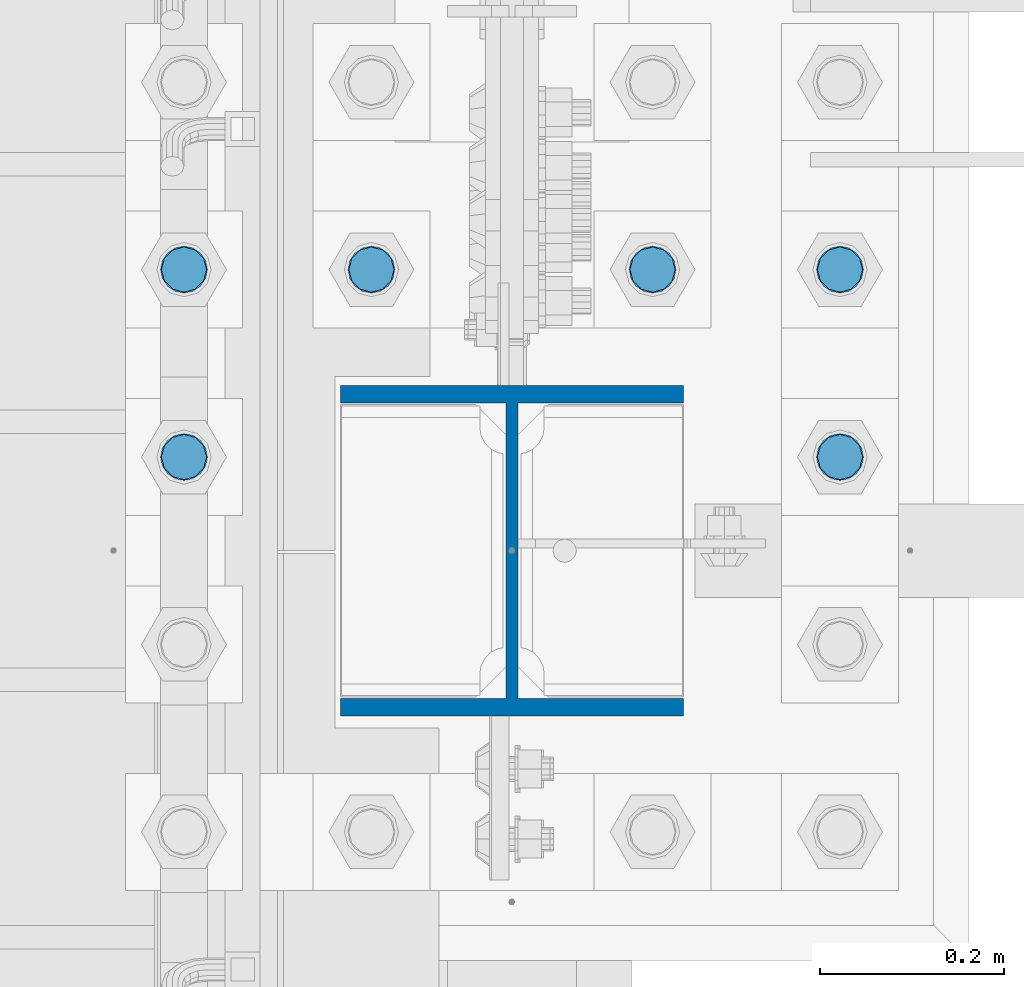
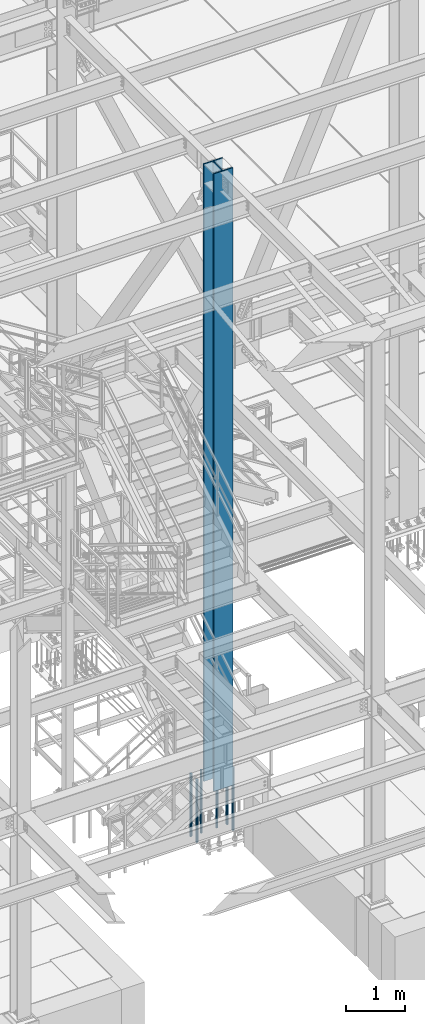
# One storey, part 1296 of 3843: 7 columns, 2 elements without a shape of their own.
"""IFC2X3 building model written with IfcOpenShell, lengths in millimetres."""

import ifcopenshell
import ifcopenshell.guid

model = None  # the IFC model being written
_history = None  # IfcOwnerHistory: only IFC2X3 demands one
_inside = {}  # id of a spatial element -> (the spatial element, [elements in it])
_under = {}  # id of a project, library or spatial element -> (it, [spatial elements below it])
_declared = {}  # id of a project -> (the project, [libraries it declares])
_typed = {}  # id of a type object -> (the type object, [elements of that type])
_made_of = {}  # id of a material, layer set ... -> (it, [elements and type objects made of it])


def new_model(schema):
    """Start an empty IFC model of exactly this schema.

    Asked for "IFC4X3", IfcOpenShell would pick the latest addendum, in which some entities
    have other attributes; the version numbers below select the first issue.
    IFC2X3 requires an IfcOwnerHistory on every rooted entity: one is made here for all.
    """
    global model, _history
    if schema == "IFC4X3":
        model = ifcopenshell.file(schema_version=(4, 3, 0, 0))
    else:
        model = ifcopenshell.file(schema=schema)
    _inside.clear()
    _under.clear()
    _declared.clear()
    _typed.clear()
    _made_of.clear()
    _history = None
    if model.schema == "IFC2X3":
        org = make("IfcOrganization", Name="unknown")
        user = make(
            "IfcPersonAndOrganization",
            ThePerson=make("IfcPerson", FamilyName="unknown"),
            TheOrganization=org,
        )
        app = make(
            "IfcApplication",
            ApplicationDeveloper=org,
            Version="unknown",
            ApplicationFullName="unknown",
            ApplicationIdentifier="unknown",
        )
        _history = make(
            "IfcOwnerHistory",
            OwningUser=user,
            OwningApplication=app,
            ChangeAction="ADDED",
            CreationDate=0,
        )
    return model


def make(cls, **values):
    """One entity of the class cls with the attributes given. An attribute that is None is left unset."""
    return model.create_entity(
        cls, **{name: value for name, value in values.items() if value is not None}
    )


def rooted(cls, **values):
    """An entity with a GlobalId (a new one), such as an element, a storey or a relation."""
    return make(cls, GlobalId=ifcopenshell.guid.new(), OwnerHistory=_history, **values)


def si_unit(unit_type, name, prefix=None):
    """IfcSIUnit, for example si_unit("LENGTHUNIT", "METRE", prefix="MILLI")."""
    return make("IfcSIUnit", UnitType=unit_type, Prefix=prefix, Name=name)


def assignment(units):
    """IfcUnitAssignment: the units of a project."""
    return None if units is None else make("IfcUnitAssignment", Units=units)


def point(xyz):
    """IfcCartesianPoint."""
    return None if xyz is None else make("IfcCartesianPoint", Coordinates=xyz)


def direction(xyz):
    """IfcDirection."""
    return None if xyz is None else make("IfcDirection", DirectionRatios=xyz)


def frame(location, z_axis=None, x_axis=None):
    """IfcAxis2Placement3D, a coordinate frame: its origin and axes. An axis left out is left unset."""
    return make(
        "IfcAxis2Placement3D",
        Location=point(location),
        Axis=direction(z_axis),
        RefDirection=direction(x_axis),
    )


def origin_with_axes():
    """The frame at (0, 0, 0) with the z axis (0, 0, 1) and the x axis (1, 0, 0) written out."""
    return frame((0.0, 0.0, 0.0), z_axis=(0.0, 0.0, 1.0), x_axis=(1.0, 0.0, 0.0))


def place(relative_to, where):
    """IfcLocalPlacement: puts the frame where relative to a parent placement (None: the world)."""
    return make(
        "IfcLocalPlacement", PlacementRelTo=relative_to, RelativePlacement=where
    )


def context(
    kind, dimensions, precision=None, world=None, true_north=None, identifier=None
):
    """IfcGeometricRepresentationContext, for example the 3D "Model" context."""
    return make(
        "IfcGeometricRepresentationContext",
        ContextIdentifier=identifier,
        ContextType=kind,
        CoordinateSpaceDimension=dimensions,
        Precision=precision,
        WorldCoordinateSystem=world,
        TrueNorth=true_north,
    )


def subcontext(parent, identifier, kind, view, scale=None):
    """IfcGeometricRepresentationSubContext, for example "Body" below "Model"."""
    return make(
        "IfcGeometricRepresentationSubContext",
        ContextIdentifier=identifier,
        ContextType=kind,
        ParentContext=parent,
        TargetScale=scale,
        TargetView=view,
    )


def project(units=None, contexts=None):
    """IfcProject with its units and contexts."""
    return rooted(
        "IfcProject",
        Name="project",
        RepresentationContexts=contexts,
        UnitsInContext=assignment(units),
    )


def spatial(cls, under=None, at=None, **own):
    """A site, building, storey or space (cls), placed at a placement, below another one or the project."""
    s = rooted(cls, ObjectPlacement=at, **own)
    if under is not None:
        _under.setdefault(under.id(), (under, []))[1].append(s)
    return s


def faces_of(points, faces, orient=None, outer=None):
    """IfcFace entities. A face is a list of loops; a loop is a list of indices into points, from 0.

    orient and outer hold one flag for each loop. By default every Orientation is true, the
    first loop of a face is its IfcFaceOuterBound and the others are IfcFaceBound.
    """
    made = []
    for i, loops in enumerate(faces):
        bounds = []
        for j, loop in enumerate(loops):
            is_outer = j == 0 if outer is None else outer[i][j]
            bounds.append(
                make(
                    "IfcFaceOuterBound" if is_outer else "IfcFaceBound",
                    Bound=make("IfcPolyLoop", Polygon=[points[k] for k in loop]),
                    Orientation=True if orient is None else orient[i][j],
                )
            )
        made.append(make("IfcFace", Bounds=bounds))
    return made


def faceted_brep(points, faces, orient=None, outer=None, voids=None):
    """IfcFacetedBrep: a solid bounded by flat faces; with voids (closed shells), ...WithVoids."""
    shared = [point(p) for p in points]
    hull = make("IfcClosedShell", CfsFaces=faces_of(shared, faces, orient, outer))
    if voids is None:
        return make("IfcFacetedBrep", Outer=hull)
    return make(
        "IfcFacetedBrepWithVoids",
        Outer=hull,
        Voids=[
            make(cls, CfsFaces=faces_of(shared, fs, o, b)) for cls, fs, o, b in voids
        ],
    )


def shape(context_of_items, identifier, shape_type, items):
    """IfcShapeRepresentation: the items that make up one representation, for example the "Body"."""
    return make(
        "IfcShapeRepresentation",
        ContextOfItems=context_of_items,
        RepresentationIdentifier=identifier,
        RepresentationType=shape_type,
        Items=items,
    )


def material(Name=None, Category=None):
    """IfcMaterial."""
    return make("IfcMaterial", Name=Name, Category=Category)


def made_of(thing, what):
    """Note that an element or type object is made of a material, layer set ...; save() writes the relation."""
    if what is not None:
        _made_of.setdefault(what.id(), (what, []))[1].append(thing)
    return thing


def type_object(cls, material=None, **own):
    """A type object (cls), such as IfcWallType, which elements share."""
    return made_of(rooted(cls, **own), material)


def element(
    cls,
    number,
    at=None,
    inside=None,
    cuts=None,
    type_object=None,
    material=None,
    context=None,
    identifier="Body",
    shape_type=None,
    held_by="IfcProductDefinitionShape",
    body=None,
    shapes=None,
    **own,
):
    """One element of the class cls, such as IfcWall. Its Tag is "e" and its number.

    at: its placement. inside: the storey or other place that contains it. cuts: it is an
    opening in that element (IfcRelVoidsElement). A single representation is given by context,
    identifier, shape_type and body (its items); several are given by shapes. held_by: the class
    of the entity that holds the representations. save() writes the other relations.
    """
    e = rooted(cls, Tag="e%d" % number, ObjectPlacement=at, **own)
    if body is not None:
        shapes = [shape(context, identifier, shape_type, body)]
    if shapes is not None:
        e.Representation = make(held_by, Representations=shapes)
    if inside is not None:
        _inside.setdefault(inside.id(), (inside, []))[1].append(e)
    if cuts is not None:
        rooted(
            "IfcRelVoidsElement", RelatingBuildingElement=cuts, RelatedOpeningElement=e
        )
    if type_object is not None:
        _typed.setdefault(type_object.id(), (type_object, []))[1].append(e)
    return made_of(e, material)


def aggregate(whole, parts):
    """IfcRelAggregates: a whole, such as a stair, and the parts it consists of."""
    return rooted("IfcRelAggregates", RelatingObject=whole, RelatedObjects=parts)


def save(model, path):
    """Write the relations noted so far, then the file.

    IfcRelAggregates (storeys below a building ...), IfcRelContainedInSpatialStructure (elements
    in a storey), IfcRelDefinesByType, IfcRelAssociatesMaterial and IfcRelDeclares: one each for
    every whole, place, type object, material and project.
    """
    for whole, parts in _under.values():
        aggregate(whole, parts)
    for where, things in _inside.values():
        rooted(
            "IfcRelContainedInSpatialStructure",
            RelatedElements=things,
            RelatingStructure=where,
        )
    for kind, things in _typed.values():
        rooted("IfcRelDefinesByType", RelatedObjects=things, RelatingType=kind)
    for what, things in _made_of.values():
        rooted("IfcRelAssociatesMaterial", RelatedObjects=things, RelatingMaterial=what)
    for by, libraries in _declared.values():
        rooted("IfcRelDeclares", RelatingContext=by, RelatedDefinitions=libraries)
    model.write(path)


model = new_model("IFC2X3")

# Units and contexts
model_context = context("Model", 3, precision=1e-05, world=origin_with_axes())
body_context = subcontext(model_context, "Body", "Model", "MODEL_VIEW")
ifc_project = project(units=[si_unit("LENGTHUNIT", "METRE", prefix="MILLI"), si_unit("AREAUNIT", "SQUARE_METRE"), si_unit("VOLUMEUNIT", "CUBIC_METRE"), si_unit("MASSUNIT", "GRAM", prefix="KILO"), si_unit("TIMEUNIT", "SECOND"), si_unit("PLANEANGLEUNIT", "RADIAN"), si_unit("SOLIDANGLEUNIT", "STERADIAN"), si_unit("THERMODYNAMICTEMPERATUREUNIT", "DEGREE_CELSIUS"), si_unit("LUMINOUSINTENSITYUNIT", "LUMEN")], contexts=[model_context])

# Site, building, storey
site_placement = place(None, origin_with_axes())
site = spatial("IfcSite", under=ifc_project, at=site_placement, CompositionType="ELEMENT")
building_placement = place(site_placement, origin_with_axes())
building = spatial("IfcBuilding", under=site, at=building_placement, Name="Undefined", CompositionType="ELEMENT")
storey_placement = place(building_placement, origin_with_axes())
storey = spatial("IfcBuildingStorey", under=building, at=storey_placement, Name="Undefined", CompositionType="ELEMENT", Elevation=0.0)

# Assembly, columns
assembly_1_placement = place(storey_placement, origin_with_axes())
assembly_1 = element("IfcElementAssembly", 1, at=assembly_1_placement, inside=storey, Name="TEMPLATE", AssemblyPlace="NOTDEFINED", PredefinedType="RIGID_FRAME")
ifc_material_1 = material(Name="Undefined/F1554-GR.55")
column_type_1 = type_object("IfcColumnType", PredefinedType="NOTDEFINED")
column_1_placement = place(assembly_1_placement, frame((55575.2, 20408.9, 29565.6), z_axis=(0.0, -1.0, 0.0), x_axis=(0.0, 0.0, -1.0)))
column_1 = element("IfcColumn", 2, at=column_1_placement, type_object=column_type_1, material=ifc_material_1, Name="ANCHOR_ROD", context=body_context, shape_type="Brep", body=[
    faceted_brep([(-260.349999999999, -21.2176223927163, 12.25), (-260.349999999999, -12.25, 21.2176223927199), (-260.349999999999, 0.0, 24.5), (-260.349999999999, 12.25, 21.2176223927199), (-260.349999999999, 21.2176223927163, 12.25), (-260.349999999999, 24.5, 0.0), (-260.349999999999, 21.2176223927163, -12.25), (-260.349999999999, 12.25, -21.2176223927199), (-260.349999999999, 0.0, -24.5), (-260.349999999999, -12.25, -21.2176223927199), (-260.349999999999, -21.2176223927163, -12.25), (-260.349999999999, -24.5, 0.0), (0.0, 24.5000000000146, 0.0), (0.0, 21.2176223927381, -12.25), (0.0, 12.2500000000146, -21.2176223927163), (0.0, 1.45519152283669e-11, -24.5), (0.0, -12.2499999999854, -21.2176223927163), (0.0, -21.217622392709, -12.25), (0.0, -24.4999999999854, 0.0), (0.0, -21.217622392709, 12.25), (0.0, -12.2499999999854, 21.2176223927163), (0.0, 1.45519152283669e-11, 24.5), (0.0, 12.2500000000146, 21.2176223927163), (0.0, 21.2176223927381, 12.25), (0.0, -23.4665401257807, 9.72015918207035), (0.0, -17.9605122421344, 17.9605122421417), (0.0, -9.72015918207762, 23.466540125788), (0.0, 0.0, 25.4000000000015), (0.0, 9.72015918207762, 23.466540125788), (0.0, 17.9605122421344, 17.9605122421417), (0.0, 23.4665401257807, 9.72015918207035), (0.0, 25.3999996185303, 0.0), (0.0, 23.4665401257807, -9.72015918207035), (0.0, 17.9605122421344, -17.9605122421417), (0.0, 9.72015918207762, -23.466540125788), (0.0, 0.0, -25.4000000000015), (0.0, -9.72015918207762, -23.466540125788), (0.0, -17.9605122421344, -17.9605122421417), (0.0, -23.4665401257807, -9.72015918207035), (0.0, -25.3999996185303, 0.0), (812.799999999999, -25.4000000000015, 0.0), (812.799999999999, -23.466540125788, 9.72015918207398), (812.799999999999, -17.9605122421417, 17.9605122421381), (812.799999999999, -9.72015918207035, 23.466540125788), (812.799999999999, 0.0, 25.4000000000015), (812.799999999999, 9.72015918207035, 23.466540125788), (812.799999999999, 17.9605122421417, 17.9605122421381), (812.799999999999, 23.466540125788, 9.72015918207398), (812.799999999999, 25.4000000000015, 0.0), (812.799999999999, 23.466540125788, -9.72015918207398), (812.799999999999, 17.9605122421417, -17.9605122421381), (812.799999999999, 9.72015918207035, -23.466540125788), (812.799999999999, 0.0, -25.4000000000015), (812.799999999999, -9.72015918207035, -23.466540125788), (812.799999999999, -17.9605122421417, -17.9605122421381), (812.799999999999, -23.466540125788, -9.72015918207398), (812.799999999999, -12.25, 21.2176223927199), (812.799999999999, 0.0, 24.5), (812.799999999999, 12.25, 21.2176223927199), (812.799999999999, 21.2176223927163, 12.25), (812.799999999999, 24.5, 0.0), (812.799999999999, 21.2176223927163, -12.25), (812.799999999999, 12.25, -21.2176223927199), (812.799999999999, 0.0, -24.5), (812.799999999999, -12.25, -21.2176223927199), (812.799999999999, -21.2176223927163, -12.25), (812.799999999999, -24.5, 0.0), (812.799999999999, -21.2176223927163, 12.25), (1041.4, -12.25, -21.2176223927199), (1041.4, 0.0, -24.5), (1041.4, 12.25, -21.2176223927199), (1041.4, 21.2176223927163, -12.25), (1041.4, 24.5, 0.0), (1041.4, 21.2176223927163, 12.25), (1041.4, 12.25, 21.2176223927199), (1041.4, 0.0, 24.5), (1041.4, -12.25, 21.2176223927199), (1041.4, -21.2176223927163, 12.25), (1041.4, -24.5, 0.0), (1041.4, -21.2176223927163, -12.25)], [[[0, 1, 2, 3, 4, 5, 6, 7, 8, 9, 10, 11]], [[6, 5, 12, 13]], [[7, 6, 13, 14]], [[8, 7, 14, 15]], [[9, 8, 15, 16]], [[10, 9, 16, 17]], [[11, 10, 17, 18]], [[0, 11, 18, 19]], [[1, 0, 19, 20]], [[2, 1, 20, 21]], [[3, 2, 21, 22]], [[4, 3, 22, 23]], [[5, 4, 23, 12]], [[24, 25, 26, 27, 28, 29, 30, 31, 32, 33, 34, 35, 36, 37, 38, 39], [22, 21, 20, 19, 18, 17, 16, 15, 14, 13, 12, 23]], [[24, 39, 40, 41]], [[25, 24, 41, 42]], [[26, 25, 42, 43]], [[27, 26, 43, 44]], [[28, 27, 44, 45]], [[29, 28, 45, 46]], [[30, 29, 46, 47]], [[31, 30, 47, 48]], [[32, 31, 48, 49]], [[33, 32, 49, 50]], [[34, 33, 50, 51]], [[35, 34, 51, 52]], [[36, 35, 52, 53]], [[37, 36, 53, 54]], [[38, 37, 54, 55]], [[39, 38, 55, 40]], [[54, 53, 52, 51, 50, 49, 48, 47, 46, 45, 44, 43, 42, 41, 40, 55], [56, 57, 58, 59, 60, 61, 62, 63, 64, 65, 66, 67]], [[68, 69, 70, 71, 72, 73, 74, 75, 76, 77, 78, 79]], [[76, 75, 57, 56]], [[77, 76, 56, 67]], [[78, 77, 67, 66]], [[79, 78, 66, 65]], [[68, 79, 65, 64]], [[69, 68, 64, 63]], [[70, 69, 63, 62]], [[71, 70, 62, 61]], [[72, 71, 61, 60]], [[73, 72, 60, 59]], [[74, 73, 59, 58]], [[75, 74, 58, 57]]]),
])
column_2_placement = place(assembly_1_placement, frame((56286.4, 20408.9, 29565.6), z_axis=(0.0, 1.0, 0.0), x_axis=(0.0, 0.0, -1.0)))
column_2 = element("IfcColumn", 3, at=column_2_placement, type_object=column_type_1, material=ifc_material_1, Name="ANCHOR_ROD", context=body_context, shape_type="Brep", body=[
    faceted_brep([(-260.349999999999, -21.2176223927163, 12.25), (-260.349999999999, -12.25, 21.2176223927199), (-260.349999999999, 0.0, 24.5), (-260.349999999999, 12.25, 21.2176223927199), (-260.349999999999, 21.2176223927163, 12.25), (-260.349999999999, 24.5, 0.0), (-260.349999999999, 21.2176223927163, -12.25), (-260.349999999999, 12.25, -21.2176223927199), (-260.349999999999, 0.0, -24.5), (-260.349999999999, -12.25, -21.2176223927199), (-260.349999999999, -21.2176223927163, -12.25), (-260.349999999999, -24.5, 0.0), (0.0, 24.5000000000146, 0.0), (0.0, 21.2176223927381, -12.25), (0.0, 12.2500000000146, -21.2176223927163), (0.0, 1.45519152283669e-11, -24.5), (0.0, -12.2499999999854, -21.2176223927163), (0.0, -21.217622392709, -12.25), (0.0, -24.4999999999854, 0.0), (0.0, -21.217622392709, 12.25), (0.0, -12.2499999999854, 21.2176223927163), (0.0, 1.45519152283669e-11, 24.5), (0.0, 12.2500000000146, 21.2176223927163), (0.0, 21.2176223927381, 12.25), (0.0, -23.4665401257807, 9.72015918207035), (0.0, -17.9605122421344, 17.9605122421417), (0.0, -9.72015918207762, 23.466540125788), (0.0, 0.0, 25.4000000000015), (0.0, 9.72015918207762, 23.466540125788), (0.0, 17.9605122421344, 17.9605122421417), (0.0, 23.4665401257807, 9.72015918207035), (0.0, 25.3999996185303, 0.0), (0.0, 23.4665401257807, -9.72015918207035), (0.0, 17.9605122421344, -17.9605122421417), (0.0, 9.72015918207762, -23.466540125788), (0.0, 0.0, -25.4000000000015), (0.0, -9.72015918207762, -23.466540125788), (0.0, -17.9605122421344, -17.9605122421417), (0.0, -23.4665401257807, -9.72015918207035), (0.0, -25.3999996185303, 0.0), (812.799999999999, -25.4000000000015, 0.0), (812.799999999999, -23.466540125788, 9.72015918207398), (812.799999999999, -17.9605122421417, 17.9605122421381), (812.799999999999, -9.72015918207035, 23.466540125788), (812.799999999999, 0.0, 25.4000000000015), (812.799999999999, 9.72015918207035, 23.466540125788), (812.799999999999, 17.9605122421417, 17.9605122421381), (812.799999999999, 23.466540125788, 9.72015918207398), (812.799999999999, 25.4000000000015, 0.0), (812.799999999999, 23.466540125788, -9.72015918207398), (812.799999999999, 17.9605122421417, -17.9605122421381), (812.799999999999, 9.72015918207035, -23.466540125788), (812.799999999999, 0.0, -25.4000000000015), (812.799999999999, -9.72015918207035, -23.466540125788), (812.799999999999, -17.9605122421417, -17.9605122421381), (812.799999999999, -23.466540125788, -9.72015918207398), (812.799999999999, -12.25, 21.2176223927199), (812.799999999999, 0.0, 24.5), (812.799999999999, 12.25, 21.2176223927199), (812.799999999999, 21.2176223927163, 12.25), (812.799999999999, 24.5, 0.0), (812.799999999999, 21.2176223927163, -12.25), (812.799999999999, 12.25, -21.2176223927199), (812.799999999999, 0.0, -24.5), (812.799999999999, -12.25, -21.2176223927199), (812.799999999999, -21.2176223927163, -12.25), (812.799999999999, -24.5, 0.0), (812.799999999999, -21.2176223927163, 12.25), (1041.4, -12.25, -21.2176223927199), (1041.4, 0.0, -24.5), (1041.4, 12.25, -21.2176223927199), (1041.4, 21.2176223927163, -12.25), (1041.4, 24.5, 0.0), (1041.4, 21.2176223927163, 12.25), (1041.4, 12.25, 21.2176223927199), (1041.4, 0.0, 24.5), (1041.4, -12.25, 21.2176223927199), (1041.4, -21.2176223927163, 12.25), (1041.4, -24.5, 0.0), (1041.4, -21.2176223927163, -12.25)], [[[0, 1, 2, 3, 4, 5, 6, 7, 8, 9, 10, 11]], [[6, 5, 12, 13]], [[7, 6, 13, 14]], [[8, 7, 14, 15]], [[9, 8, 15, 16]], [[10, 9, 16, 17]], [[11, 10, 17, 18]], [[0, 11, 18, 19]], [[1, 0, 19, 20]], [[2, 1, 20, 21]], [[3, 2, 21, 22]], [[4, 3, 22, 23]], [[5, 4, 23, 12]], [[24, 25, 26, 27, 28, 29, 30, 31, 32, 33, 34, 35, 36, 37, 38, 39], [22, 21, 20, 19, 18, 17, 16, 15, 14, 13, 12, 23]], [[24, 39, 40, 41]], [[25, 24, 41, 42]], [[26, 25, 42, 43]], [[27, 26, 43, 44]], [[28, 27, 44, 45]], [[29, 28, 45, 46]], [[30, 29, 46, 47]], [[31, 30, 47, 48]], [[32, 31, 48, 49]], [[33, 32, 49, 50]], [[34, 33, 50, 51]], [[35, 34, 51, 52]], [[36, 35, 52, 53]], [[37, 36, 53, 54]], [[38, 37, 54, 55]], [[39, 38, 55, 40]], [[54, 53, 52, 51, 50, 49, 48, 47, 46, 45, 44, 43, 42, 41, 40, 55], [56, 57, 58, 59, 60, 61, 62, 63, 64, 65, 66, 67]], [[68, 69, 70, 71, 72, 73, 74, 75, 76, 77, 78, 79]], [[76, 75, 57, 56]], [[77, 76, 56, 67]], [[78, 77, 67, 66]], [[79, 78, 66, 65]], [[68, 79, 65, 64]], [[69, 68, 64, 63]], [[70, 69, 63, 62]], [[71, 70, 62, 61]], [[72, 71, 61, 60]], [[73, 72, 60, 59]], [[74, 73, 59, 58]], [[75, 74, 58, 57]]]),
])
column_3_placement = place(assembly_1_placement, frame((55575.2, 20612.1, 29565.6), z_axis=(0.0, -1.0, 0.0), x_axis=(0.0, 0.0, -1.0)))
column_3 = element("IfcColumn", 4, at=column_3_placement, type_object=column_type_1, material=ifc_material_1, Name="ANCHOR_ROD", context=body_context, shape_type="Brep", body=[
    faceted_brep([(-260.349999999999, -21.2176223927163, 12.25), (-260.349999999999, -12.25, 21.2176223927199), (-260.349999999999, 0.0, 24.5), (-260.349999999999, 12.25, 21.2176223927199), (-260.349999999999, 21.2176223927163, 12.25), (-260.349999999999, 24.5, 0.0), (-260.349999999999, 21.2176223927163, -12.25), (-260.349999999999, 12.25, -21.2176223927199), (-260.349999999999, 0.0, -24.5), (-260.349999999999, -12.25, -21.2176223927199), (-260.349999999999, -21.2176223927163, -12.25), (-260.349999999999, -24.5, 0.0), (0.0, 24.5000000000146, 0.0), (0.0, 21.2176223927381, -12.25), (0.0, 12.2500000000146, -21.2176223927163), (0.0, 1.45519152283669e-11, -24.5), (0.0, -12.2499999999854, -21.2176223927163), (0.0, -21.217622392709, -12.25), (0.0, -24.4999999999854, 0.0), (0.0, -21.217622392709, 12.25), (0.0, -12.2499999999854, 21.2176223927163), (0.0, 1.45519152283669e-11, 24.5), (0.0, 12.2500000000146, 21.2176223927163), (0.0, 21.2176223927381, 12.25), (0.0, -23.4665401257807, 9.72015918207035), (0.0, -17.9605122421344, 17.9605122421417), (0.0, -9.72015918207762, 23.466540125788), (0.0, 0.0, 25.4000000000015), (0.0, 9.72015918207762, 23.466540125788), (0.0, 17.9605122421344, 17.9605122421417), (0.0, 23.4665401257807, 9.72015918207035), (0.0, 25.3999996185303, 0.0), (0.0, 23.4665401257807, -9.72015918207035), (0.0, 17.9605122421344, -17.9605122421417), (0.0, 9.72015918207762, -23.466540125788), (0.0, 0.0, -25.4000000000015), (0.0, -9.72015918207762, -23.466540125788), (0.0, -17.9605122421344, -17.9605122421417), (0.0, -23.4665401257807, -9.72015918207035), (0.0, -25.3999996185303, 0.0), (812.799999999999, -25.4000000000015, 0.0), (812.799999999999, -23.466540125788, 9.72015918207398), (812.799999999999, -17.9605122421417, 17.9605122421381), (812.799999999999, -9.72015918207035, 23.466540125788), (812.799999999999, 0.0, 25.4000000000015), (812.799999999999, 9.72015918207035, 23.466540125788), (812.799999999999, 17.9605122421417, 17.9605122421381), (812.799999999999, 23.466540125788, 9.72015918207398), (812.799999999999, 25.4000000000015, 0.0), (812.799999999999, 23.466540125788, -9.72015918207398), (812.799999999999, 17.9605122421417, -17.9605122421381), (812.799999999999, 9.72015918207035, -23.466540125788), (812.799999999999, 0.0, -25.4000000000015), (812.799999999999, -9.72015918207035, -23.466540125788), (812.799999999999, -17.9605122421417, -17.9605122421381), (812.799999999999, -23.466540125788, -9.72015918207398), (812.799999999999, -12.25, 21.2176223927199), (812.799999999999, 0.0, 24.5), (812.799999999999, 12.25, 21.2176223927199), (812.799999999999, 21.2176223927163, 12.25), (812.799999999999, 24.5, 0.0), (812.799999999999, 21.2176223927163, -12.25), (812.799999999999, 12.25, -21.2176223927199), (812.799999999999, 0.0, -24.5), (812.799999999999, -12.25, -21.2176223927199), (812.799999999999, -21.2176223927163, -12.25), (812.799999999999, -24.5, 0.0), (812.799999999999, -21.2176223927163, 12.25), (1041.4, -12.25, -21.2176223927199), (1041.4, 0.0, -24.5), (1041.4, 12.25, -21.2176223927199), (1041.4, 21.2176223927163, -12.25), (1041.4, 24.5, 0.0), (1041.4, 21.2176223927163, 12.25), (1041.4, 12.25, 21.2176223927199), (1041.4, 0.0, 24.5), (1041.4, -12.25, 21.2176223927199), (1041.4, -21.2176223927163, 12.25), (1041.4, -24.5, 0.0), (1041.4, -21.2176223927163, -12.25)], [[[0, 1, 2, 3, 4, 5, 6, 7, 8, 9, 10, 11]], [[6, 5, 12, 13]], [[7, 6, 13, 14]], [[8, 7, 14, 15]], [[9, 8, 15, 16]], [[10, 9, 16, 17]], [[11, 10, 17, 18]], [[0, 11, 18, 19]], [[1, 0, 19, 20]], [[2, 1, 20, 21]], [[3, 2, 21, 22]], [[4, 3, 22, 23]], [[5, 4, 23, 12]], [[24, 25, 26, 27, 28, 29, 30, 31, 32, 33, 34, 35, 36, 37, 38, 39], [22, 21, 20, 19, 18, 17, 16, 15, 14, 13, 12, 23]], [[24, 39, 40, 41]], [[25, 24, 41, 42]], [[26, 25, 42, 43]], [[27, 26, 43, 44]], [[28, 27, 44, 45]], [[29, 28, 45, 46]], [[30, 29, 46, 47]], [[31, 30, 47, 48]], [[32, 31, 48, 49]], [[33, 32, 49, 50]], [[34, 33, 50, 51]], [[35, 34, 51, 52]], [[36, 35, 52, 53]], [[37, 36, 53, 54]], [[38, 37, 54, 55]], [[39, 38, 55, 40]], [[54, 53, 52, 51, 50, 49, 48, 47, 46, 45, 44, 43, 42, 41, 40, 55], [56, 57, 58, 59, 60, 61, 62, 63, 64, 65, 66, 67]], [[68, 69, 70, 71, 72, 73, 74, 75, 76, 77, 78, 79]], [[76, 75, 57, 56]], [[77, 76, 56, 67]], [[78, 77, 67, 66]], [[79, 78, 66, 65]], [[68, 79, 65, 64]], [[69, 68, 64, 63]], [[70, 69, 63, 62]], [[71, 70, 62, 61]], [[72, 71, 61, 60]], [[73, 72, 60, 59]], [[74, 73, 59, 58]], [[75, 74, 58, 57]]]),
])
column_4_placement = place(assembly_1_placement, frame((55778.4, 20612.1, 29565.6), z_axis=(0.0, -1.0, 0.0), x_axis=(0.0, 0.0, -1.0)))
column_4 = element("IfcColumn", 5, at=column_4_placement, type_object=column_type_1, material=ifc_material_1, Name="ANCHOR_ROD", context=body_context, shape_type="Brep", body=[
    faceted_brep([(-260.349999999999, -21.2176223927163, 12.25), (-260.349999999999, -12.25, 21.2176223927199), (-260.349999999999, 0.0, 24.5), (-260.349999999999, 12.25, 21.2176223927199), (-260.349999999999, 21.2176223927163, 12.25), (-260.349999999999, 24.5, 0.0), (-260.349999999999, 21.2176223927163, -12.25), (-260.349999999999, 12.25, -21.2176223927199), (-260.349999999999, 0.0, -24.5), (-260.349999999999, -12.25, -21.2176223927199), (-260.349999999999, -21.2176223927163, -12.25), (-260.349999999999, -24.5, 0.0), (0.0, 24.5000000000146, 0.0), (0.0, 21.2176223927381, -12.25), (0.0, 12.2500000000146, -21.2176223927163), (0.0, 1.45519152283669e-11, -24.5), (0.0, -12.2499999999854, -21.2176223927163), (0.0, -21.217622392709, -12.25), (0.0, -24.4999999999854, 0.0), (0.0, -21.217622392709, 12.25), (0.0, -12.2499999999854, 21.2176223927163), (0.0, 1.45519152283669e-11, 24.5), (0.0, 12.2500000000146, 21.2176223927163), (0.0, 21.2176223927381, 12.25), (0.0, -23.4665401257807, 9.72015918207035), (0.0, -17.9605122421344, 17.9605122421417), (0.0, -9.72015918207762, 23.466540125788), (0.0, 0.0, 25.4000000000015), (0.0, 9.72015918207762, 23.466540125788), (0.0, 17.9605122421344, 17.9605122421417), (0.0, 23.4665401257807, 9.72015918207035), (0.0, 25.3999996185303, 0.0), (0.0, 23.4665401257807, -9.72015918207035), (0.0, 17.9605122421344, -17.9605122421417), (0.0, 9.72015918207762, -23.466540125788), (0.0, 0.0, -25.4000000000015), (0.0, -9.72015918207762, -23.466540125788), (0.0, -17.9605122421344, -17.9605122421417), (0.0, -23.4665401257807, -9.72015918207035), (0.0, -25.3999996185303, 0.0), (812.799999999999, -25.4000000000015, 0.0), (812.799999999999, -23.466540125788, 9.72015918207398), (812.799999999999, -17.9605122421417, 17.9605122421381), (812.799999999999, -9.72015918207035, 23.466540125788), (812.799999999999, 0.0, 25.4000000000015), (812.799999999999, 9.72015918207035, 23.466540125788), (812.799999999999, 17.9605122421417, 17.9605122421381), (812.799999999999, 23.466540125788, 9.72015918207398), (812.799999999999, 25.4000000000015, 0.0), (812.799999999999, 23.466540125788, -9.72015918207398), (812.799999999999, 17.9605122421417, -17.9605122421381), (812.799999999999, 9.72015918207035, -23.466540125788), (812.799999999999, 0.0, -25.4000000000015), (812.799999999999, -9.72015918207035, -23.466540125788), (812.799999999999, -17.9605122421417, -17.9605122421381), (812.799999999999, -23.466540125788, -9.72015918207398), (812.799999999999, -12.25, 21.2176223927199), (812.799999999999, 0.0, 24.5), (812.799999999999, 12.25, 21.2176223927199), (812.799999999999, 21.2176223927163, 12.25), (812.799999999999, 24.5, 0.0), (812.799999999999, 21.2176223927163, -12.25), (812.799999999999, 12.25, -21.2176223927199), (812.799999999999, 0.0, -24.5), (812.799999999999, -12.25, -21.2176223927199), (812.799999999999, -21.2176223927163, -12.25), (812.799999999999, -24.5, 0.0), (812.799999999999, -21.2176223927163, 12.25), (1041.4, -12.25, -21.2176223927199), (1041.4, 0.0, -24.5), (1041.4, 12.25, -21.2176223927199), (1041.4, 21.2176223927163, -12.25), (1041.4, 24.5, 0.0), (1041.4, 21.2176223927163, 12.25), (1041.4, 12.25, 21.2176223927199), (1041.4, 0.0, 24.5), (1041.4, -12.25, 21.2176223927199), (1041.4, -21.2176223927163, 12.25), (1041.4, -24.5, 0.0), (1041.4, -21.2176223927163, -12.25)], [[[0, 1, 2, 3, 4, 5, 6, 7, 8, 9, 10, 11]], [[6, 5, 12, 13]], [[7, 6, 13, 14]], [[8, 7, 14, 15]], [[9, 8, 15, 16]], [[10, 9, 16, 17]], [[11, 10, 17, 18]], [[0, 11, 18, 19]], [[1, 0, 19, 20]], [[2, 1, 20, 21]], [[3, 2, 21, 22]], [[4, 3, 22, 23]], [[5, 4, 23, 12]], [[24, 25, 26, 27, 28, 29, 30, 31, 32, 33, 34, 35, 36, 37, 38, 39], [22, 21, 20, 19, 18, 17, 16, 15, 14, 13, 12, 23]], [[24, 39, 40, 41]], [[25, 24, 41, 42]], [[26, 25, 42, 43]], [[27, 26, 43, 44]], [[28, 27, 44, 45]], [[29, 28, 45, 46]], [[30, 29, 46, 47]], [[31, 30, 47, 48]], [[32, 31, 48, 49]], [[33, 32, 49, 50]], [[34, 33, 50, 51]], [[35, 34, 51, 52]], [[36, 35, 52, 53]], [[37, 36, 53, 54]], [[38, 37, 54, 55]], [[39, 38, 55, 40]], [[54, 53, 52, 51, 50, 49, 48, 47, 46, 45, 44, 43, 42, 41, 40, 55], [56, 57, 58, 59, 60, 61, 62, 63, 64, 65, 66, 67]], [[68, 69, 70, 71, 72, 73, 74, 75, 76, 77, 78, 79]], [[76, 75, 57, 56]], [[77, 76, 56, 67]], [[78, 77, 67, 66]], [[79, 78, 66, 65]], [[68, 79, 65, 64]], [[69, 68, 64, 63]], [[70, 69, 63, 62]], [[71, 70, 62, 61]], [[72, 71, 61, 60]], [[73, 72, 60, 59]], [[74, 73, 59, 58]], [[75, 74, 58, 57]]]),
])
column_5_placement = place(assembly_1_placement, frame((56083.2, 20612.1, 29565.6), z_axis=(0.0, 1.0, 0.0), x_axis=(0.0, 0.0, -1.0)))
column_5 = element("IfcColumn", 6, at=column_5_placement, type_object=column_type_1, material=ifc_material_1, Name="ANCHOR_ROD", context=body_context, shape_type="Brep", body=[
    faceted_brep([(-260.349999999999, -21.2176223927163, 12.25), (-260.349999999999, -12.25, 21.2176223927199), (-260.349999999999, 0.0, 24.5), (-260.349999999999, 12.25, 21.2176223927199), (-260.349999999999, 21.2176223927163, 12.25), (-260.349999999999, 24.5, 0.0), (-260.349999999999, 21.2176223927163, -12.25), (-260.349999999999, 12.25, -21.2176223927199), (-260.349999999999, 0.0, -24.5), (-260.349999999999, -12.25, -21.2176223927199), (-260.349999999999, -21.2176223927163, -12.25), (-260.349999999999, -24.5, 0.0), (0.0, 24.5000000000146, 0.0), (0.0, 21.2176223927381, -12.25), (0.0, 12.2500000000146, -21.2176223927163), (0.0, 1.45519152283669e-11, -24.5), (0.0, -12.2499999999854, -21.2176223927163), (0.0, -21.217622392709, -12.25), (0.0, -24.4999999999854, 0.0), (0.0, -21.217622392709, 12.25), (0.0, -12.2499999999854, 21.2176223927163), (0.0, 1.45519152283669e-11, 24.5), (0.0, 12.2500000000146, 21.2176223927163), (0.0, 21.2176223927381, 12.25), (0.0, -23.4665401257807, 9.72015918207035), (0.0, -17.9605122421344, 17.9605122421417), (0.0, -9.72015918207762, 23.466540125788), (0.0, 0.0, 25.4000000000015), (0.0, 9.72015918207762, 23.466540125788), (0.0, 17.9605122421344, 17.9605122421417), (0.0, 23.4665401257807, 9.72015918207035), (0.0, 25.3999996185303, 0.0), (0.0, 23.4665401257807, -9.72015918207035), (0.0, 17.9605122421344, -17.9605122421417), (0.0, 9.72015918207762, -23.466540125788), (0.0, 0.0, -25.4000000000015), (0.0, -9.72015918207762, -23.466540125788), (0.0, -17.9605122421344, -17.9605122421417), (0.0, -23.4665401257807, -9.72015918207035), (0.0, -25.3999996185303, 0.0), (812.799999999999, -25.4000000000015, 0.0), (812.799999999999, -23.466540125788, 9.72015918207398), (812.799999999999, -17.9605122421417, 17.9605122421381), (812.799999999999, -9.72015918207035, 23.466540125788), (812.799999999999, 0.0, 25.4000000000015), (812.799999999999, 9.72015918207035, 23.466540125788), (812.799999999999, 17.9605122421417, 17.9605122421381), (812.799999999999, 23.466540125788, 9.72015918207398), (812.799999999999, 25.4000000000015, 0.0), (812.799999999999, 23.466540125788, -9.72015918207398), (812.799999999999, 17.9605122421417, -17.9605122421381), (812.799999999999, 9.72015918207035, -23.466540125788), (812.799999999999, 0.0, -25.4000000000015), (812.799999999999, -9.72015918207035, -23.466540125788), (812.799999999999, -17.9605122421417, -17.9605122421381), (812.799999999999, -23.466540125788, -9.72015918207398), (812.799999999999, -12.25, 21.2176223927199), (812.799999999999, 0.0, 24.5), (812.799999999999, 12.25, 21.2176223927199), (812.799999999999, 21.2176223927163, 12.25), (812.799999999999, 24.5, 0.0), (812.799999999999, 21.2176223927163, -12.25), (812.799999999999, 12.25, -21.2176223927199), (812.799999999999, 0.0, -24.5), (812.799999999999, -12.25, -21.2176223927199), (812.799999999999, -21.2176223927163, -12.25), (812.799999999999, -24.5, 0.0), (812.799999999999, -21.2176223927163, 12.25), (1041.4, -12.25, -21.2176223927199), (1041.4, 0.0, -24.5), (1041.4, 12.25, -21.2176223927199), (1041.4, 21.2176223927163, -12.25), (1041.4, 24.5, 0.0), (1041.4, 21.2176223927163, 12.25), (1041.4, 12.25, 21.2176223927199), (1041.4, 0.0, 24.5), (1041.4, -12.25, 21.2176223927199), (1041.4, -21.2176223927163, 12.25), (1041.4, -24.5, 0.0), (1041.4, -21.2176223927163, -12.25)], [[[0, 1, 2, 3, 4, 5, 6, 7, 8, 9, 10, 11]], [[6, 5, 12, 13]], [[7, 6, 13, 14]], [[8, 7, 14, 15]], [[9, 8, 15, 16]], [[10, 9, 16, 17]], [[11, 10, 17, 18]], [[0, 11, 18, 19]], [[1, 0, 19, 20]], [[2, 1, 20, 21]], [[3, 2, 21, 22]], [[4, 3, 22, 23]], [[5, 4, 23, 12]], [[24, 25, 26, 27, 28, 29, 30, 31, 32, 33, 34, 35, 36, 37, 38, 39], [22, 21, 20, 19, 18, 17, 16, 15, 14, 13, 12, 23]], [[24, 39, 40, 41]], [[25, 24, 41, 42]], [[26, 25, 42, 43]], [[27, 26, 43, 44]], [[28, 27, 44, 45]], [[29, 28, 45, 46]], [[30, 29, 46, 47]], [[31, 30, 47, 48]], [[32, 31, 48, 49]], [[33, 32, 49, 50]], [[34, 33, 50, 51]], [[35, 34, 51, 52]], [[36, 35, 52, 53]], [[37, 36, 53, 54]], [[38, 37, 54, 55]], [[39, 38, 55, 40]], [[54, 53, 52, 51, 50, 49, 48, 47, 46, 45, 44, 43, 42, 41, 40, 55], [56, 57, 58, 59, 60, 61, 62, 63, 64, 65, 66, 67]], [[68, 69, 70, 71, 72, 73, 74, 75, 76, 77, 78, 79]], [[76, 75, 57, 56]], [[77, 76, 56, 67]], [[78, 77, 67, 66]], [[79, 78, 66, 65]], [[68, 79, 65, 64]], [[69, 68, 64, 63]], [[70, 69, 63, 62]], [[71, 70, 62, 61]], [[72, 71, 61, 60]], [[73, 72, 60, 59]], [[74, 73, 59, 58]], [[75, 74, 58, 57]]]),
])
column_6_placement = place(assembly_1_placement, frame((56286.4, 20612.1, 29565.6), z_axis=(0.0, 1.0, 0.0), x_axis=(0.0, 0.0, -1.0)))
column_6 = element("IfcColumn", 7, at=column_6_placement, type_object=column_type_1, material=ifc_material_1, Name="ANCHOR_ROD", context=body_context, shape_type="Brep", body=[
    faceted_brep([(-260.349999999999, -21.2176223927163, 12.25), (-260.349999999999, -12.25, 21.2176223927199), (-260.349999999999, 0.0, 24.5), (-260.349999999999, 12.25, 21.2176223927199), (-260.349999999999, 21.2176223927163, 12.25), (-260.349999999999, 24.5, 0.0), (-260.349999999999, 21.2176223927163, -12.25), (-260.349999999999, 12.25, -21.2176223927199), (-260.349999999999, 0.0, -24.5), (-260.349999999999, -12.25, -21.2176223927199), (-260.349999999999, -21.2176223927163, -12.25), (-260.349999999999, -24.5, 0.0), (0.0, 24.5000000000146, 0.0), (0.0, 21.2176223927381, -12.25), (0.0, 12.2500000000146, -21.2176223927163), (0.0, 1.45519152283669e-11, -24.5), (0.0, -12.2499999999854, -21.2176223927163), (0.0, -21.217622392709, -12.25), (0.0, -24.4999999999854, 0.0), (0.0, -21.217622392709, 12.25), (0.0, -12.2499999999854, 21.2176223927163), (0.0, 1.45519152283669e-11, 24.5), (0.0, 12.2500000000146, 21.2176223927163), (0.0, 21.2176223927381, 12.25), (0.0, -23.4665401257807, 9.72015918207035), (0.0, -17.9605122421344, 17.9605122421417), (0.0, -9.72015918207762, 23.466540125788), (0.0, 0.0, 25.4000000000015), (0.0, 9.72015918207762, 23.466540125788), (0.0, 17.9605122421344, 17.9605122421417), (0.0, 23.4665401257807, 9.72015918207035), (0.0, 25.3999996185303, 0.0), (0.0, 23.4665401257807, -9.72015918207035), (0.0, 17.9605122421344, -17.9605122421417), (0.0, 9.72015918207762, -23.466540125788), (0.0, 0.0, -25.4000000000015), (0.0, -9.72015918207762, -23.466540125788), (0.0, -17.9605122421344, -17.9605122421417), (0.0, -23.4665401257807, -9.72015918207035), (0.0, -25.3999996185303, 0.0), (812.799999999999, -25.4000000000015, 0.0), (812.799999999999, -23.466540125788, 9.72015918207398), (812.799999999999, -17.9605122421417, 17.9605122421381), (812.799999999999, -9.72015918207035, 23.466540125788), (812.799999999999, 0.0, 25.4000000000015), (812.799999999999, 9.72015918207035, 23.466540125788), (812.799999999999, 17.9605122421417, 17.9605122421381), (812.799999999999, 23.466540125788, 9.72015918207398), (812.799999999999, 25.4000000000015, 0.0), (812.799999999999, 23.466540125788, -9.72015918207398), (812.799999999999, 17.9605122421417, -17.9605122421381), (812.799999999999, 9.72015918207035, -23.466540125788), (812.799999999999, 0.0, -25.4000000000015), (812.799999999999, -9.72015918207035, -23.466540125788), (812.799999999999, -17.9605122421417, -17.9605122421381), (812.799999999999, -23.466540125788, -9.72015918207398), (812.799999999999, -12.25, 21.2176223927199), (812.799999999999, 0.0, 24.5), (812.799999999999, 12.25, 21.2176223927199), (812.799999999999, 21.2176223927163, 12.25), (812.799999999999, 24.5, 0.0), (812.799999999999, 21.2176223927163, -12.25), (812.799999999999, 12.25, -21.2176223927199), (812.799999999999, 0.0, -24.5), (812.799999999999, -12.25, -21.2176223927199), (812.799999999999, -21.2176223927163, -12.25), (812.799999999999, -24.5, 0.0), (812.799999999999, -21.2176223927163, 12.25), (1041.4, -12.25, -21.2176223927199), (1041.4, 0.0, -24.5), (1041.4, 12.25, -21.2176223927199), (1041.4, 21.2176223927163, -12.25), (1041.4, 24.5, 0.0), (1041.4, 21.2176223927163, 12.25), (1041.4, 12.25, 21.2176223927199), (1041.4, 0.0, 24.5), (1041.4, -12.25, 21.2176223927199), (1041.4, -21.2176223927163, 12.25), (1041.4, -24.5, 0.0), (1041.4, -21.2176223927163, -12.25)], [[[0, 1, 2, 3, 4, 5, 6, 7, 8, 9, 10, 11]], [[6, 5, 12, 13]], [[7, 6, 13, 14]], [[8, 7, 14, 15]], [[9, 8, 15, 16]], [[10, 9, 16, 17]], [[11, 10, 17, 18]], [[0, 11, 18, 19]], [[1, 0, 19, 20]], [[2, 1, 20, 21]], [[3, 2, 21, 22]], [[4, 3, 22, 23]], [[5, 4, 23, 12]], [[24, 25, 26, 27, 28, 29, 30, 31, 32, 33, 34, 35, 36, 37, 38, 39], [22, 21, 20, 19, 18, 17, 16, 15, 14, 13, 12, 23]], [[24, 39, 40, 41]], [[25, 24, 41, 42]], [[26, 25, 42, 43]], [[27, 26, 43, 44]], [[28, 27, 44, 45]], [[29, 28, 45, 46]], [[30, 29, 46, 47]], [[31, 30, 47, 48]], [[32, 31, 48, 49]], [[33, 32, 49, 50]], [[34, 33, 50, 51]], [[35, 34, 51, 52]], [[36, 35, 52, 53]], [[37, 36, 53, 54]], [[38, 37, 54, 55]], [[39, 38, 55, 40]], [[54, 53, 52, 51, 50, 49, 48, 47, 46, 45, 44, 43, 42, 41, 40, 55], [56, 57, 58, 59, 60, 61, 62, 63, 64, 65, 66, 67]], [[68, 69, 70, 71, 72, 73, 74, 75, 76, 77, 78, 79]], [[76, 75, 57, 56]], [[77, 76, 56, 67]], [[78, 77, 67, 66]], [[79, 78, 66, 65]], [[68, 79, 65, 64]], [[69, 68, 64, 63]], [[70, 69, 63, 62]], [[71, 70, 62, 61]], [[72, 71, 61, 60]], [[73, 72, 60, 59]], [[74, 73, 59, 58]], [[75, 74, 58, 57]]]),
])
aggregate(assembly_1, [column_1, column_2, column_3, column_4, column_5, column_6])

# Assembly, column
assembly_2_placement = place(storey_placement, origin_with_axes())
assembly_2 = element("IfcElementAssembly", 8, at=assembly_2_placement, inside=storey, Name="COLUMN", AssemblyPlace="NOTDEFINED", PredefinedType="RIGID_FRAME")
ifc_material_2 = material(Name="STEEL/A992")
column_type_2 = type_object("IfcColumnType", Name="W14X99", PredefinedType="NOTDEFINED")
column_7_placement = place(assembly_2_placement, frame((55930.8, 20307.3, 29565.6), z_axis=(0.0, 1.0, 0.0), x_axis=(0.0, 0.0, 1.0)))
column_7 = element("IfcColumn", 9, at=column_7_placement, type_object=column_type_2, material=ifc_material_2, Name="COLUMN", ObjectType="W14X99", context=body_context, shape_type="Brep", body=[
    faceted_brep([(114.299999999996, 185.737500000003, -179.387500000001), (114.30000000001, 185.737500000003, -160.337500000001), (12903.2, 185.737500000003, -160.337500000001), (12903.2, 185.737500000003, -179.387500000001), (114.299999999996, 6.34999999999854, -160.337500000001), (12903.2, 6.34999999999854, -160.337500000001), (114.299999999996, 6.34999999999854, 160.337500000001), (12903.2, 6.34999999999854, 160.337500000001), (114.30000000001, 185.737500000003, 160.337500000001), (12903.2, 185.737500000003, 160.337500000001), (114.299999999996, 185.737500000003, 179.387500000001), (12903.2, 185.737500000003, 179.387500000001), (114.299999999996, -185.737500000003, 179.387500000001), (12903.2, -185.737500000003, 179.387500000001), (114.30000000001, -185.737500000003, 160.337500000001), (12903.2, -185.737500000003, 160.337500000001), (114.299999999996, -6.34999999999854, 160.337500000001), (12903.2, -6.34999999999854, 160.337500000001), (114.299999999996, -6.34999999999854, -160.337500000001), (12903.2, -6.34999999999854, -160.337500000001), (114.30000000001, -185.737500000003, -160.337500000001), (12903.2, -185.737500000003, -160.337500000001), (114.299999999996, -185.737500000003, -179.387500000001), (12903.2, -185.737500000003, -179.387500000001)], [[[0, 1, 2, 3]], [[1, 4, 5, 2]], [[4, 6, 7, 5]], [[6, 8, 9, 7]], [[8, 10, 11, 9]], [[10, 12, 13, 11]], [[12, 14, 15, 13]], [[14, 16, 17, 15]], [[16, 18, 19, 17]], [[18, 20, 21, 19]], [[20, 22, 23, 21]], [[22, 0, 3, 23]], [[5, 7, 9, 11, 13, 15, 17, 19, 21, 23, 3, 2]], [[22, 20, 18, 16, 14, 12, 10, 8, 6, 4, 1, 0]]]),
])
aggregate(assembly_2, [column_7])

save(model, "model.ifc")
